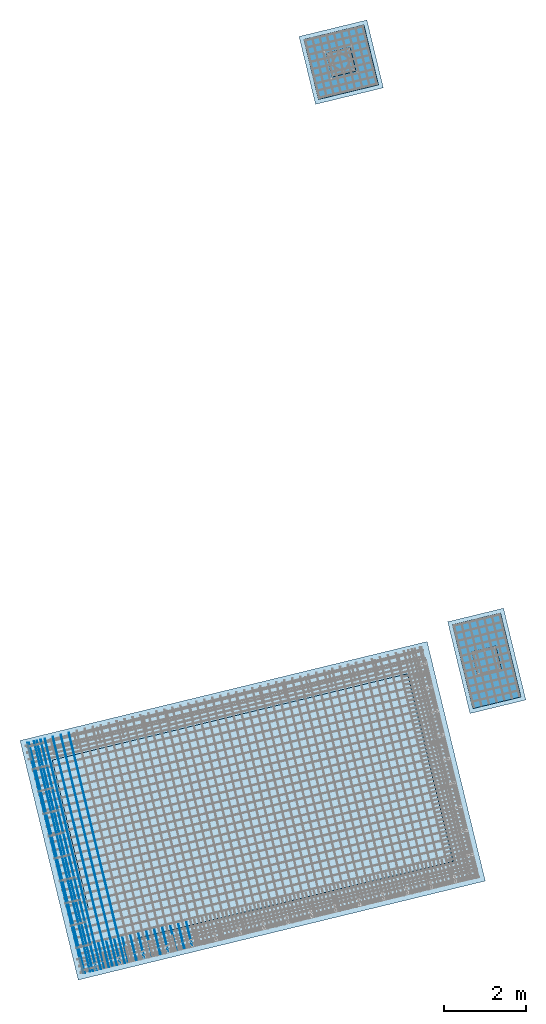
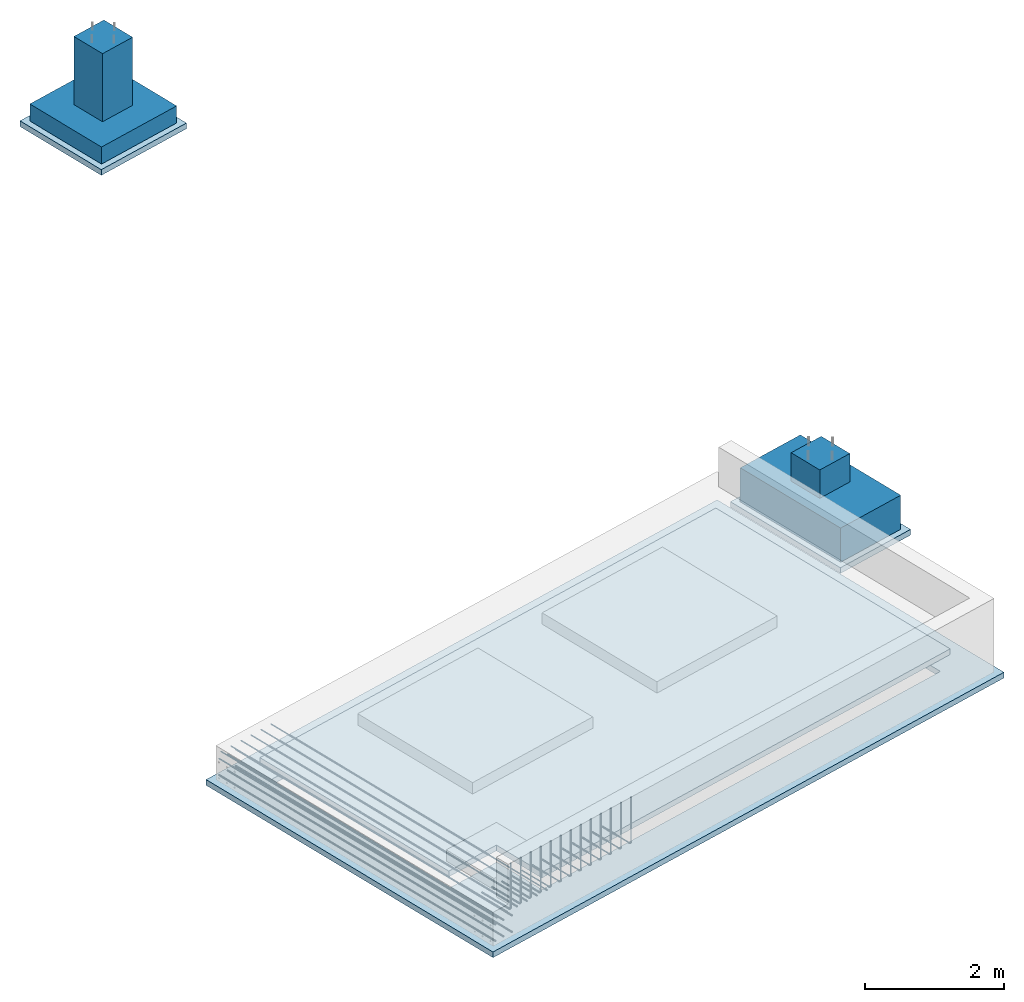
# One storey, part 1 of 25: 25 reinforcing bars, 6 slabs, 1 opening.
"""IFC2X3 building model written with IfcOpenShell, lengths in millimetres."""

from ifc_helpers import new_model, entity, si_unit, converted_unit, derived_unit, direction, frame, frame_2d, origin, origin_2d_with_axis, place, context, subcontext, project, spatial, polyline, rectangle, outline, extrude, faceted_brep, material, layer, layer_set, layer_usage, type_object, element, save


model = new_model("IFC2X3")

# Units and contexts
model_context = context("Model", 3, precision=0.01, world=origin(), true_north=direction((6.12303176911189e-17, 1.0)))
body_context = subcontext(model_context, "Body", "Model", "MODEL_VIEW")
ifc_project = project(units=[si_unit("LENGTHUNIT", "METRE", prefix="MILLI"), si_unit("AREAUNIT", "SQUARE_METRE"), si_unit("VOLUMEUNIT", "CUBIC_METRE"), converted_unit("PLANEANGLEUNIT", "DEGREE", entity("IfcRatioMeasure", 0.0174532925199433), si_unit("PLANEANGLEUNIT", "RADIAN"), dimensions=[0, 0, 0, 0, 0, 0, 0]), si_unit("MASSUNIT", "GRAM", prefix="KILO"), derived_unit("MASSDENSITYUNIT", [(si_unit("MASSUNIT", "GRAM", prefix="KILO"), 1), (si_unit("LENGTHUNIT", "METRE"), -3)]), derived_unit("MOMENTOFINERTIAUNIT", [(si_unit("LENGTHUNIT", "METRE"), 4)]), si_unit("TIMEUNIT", "SECOND"), si_unit("FREQUENCYUNIT", "HERTZ"), si_unit("THERMODYNAMICTEMPERATUREUNIT", "DEGREE_CELSIUS"), derived_unit("THERMALTRANSMITTANCEUNIT", [(si_unit("MASSUNIT", "GRAM", prefix="KILO"), 1), (si_unit("THERMODYNAMICTEMPERATUREUNIT", "KELVIN"), -1), (si_unit("TIMEUNIT", "SECOND"), -3)]), derived_unit("VOLUMETRICFLOWRATEUNIT", [(si_unit("LENGTHUNIT", "METRE"), 3), (si_unit("TIMEUNIT", "SECOND"), -1)]), derived_unit("MASSFLOWRATEUNIT", [(si_unit("MASSUNIT", "GRAM", prefix="KILO"), 1), (si_unit("TIMEUNIT", "SECOND"), -1)]), derived_unit("ROTATIONALFREQUENCYUNIT", [(si_unit("TIMEUNIT", "SECOND"), -1)]), si_unit("ELECTRICCURRENTUNIT", "AMPERE"), si_unit("ELECTRICVOLTAGEUNIT", "VOLT"), si_unit("POWERUNIT", "WATT"), si_unit("FORCEUNIT", "NEWTON", prefix="KILO"), si_unit("ILLUMINANCEUNIT", "LUX"), si_unit("LUMINOUSFLUXUNIT", "LUMEN"), si_unit("LUMINOUSINTENSITYUNIT", "CANDELA"), derived_unit("USERDEFINED", [(si_unit("MASSUNIT", "GRAM", prefix="KILO"), -1), (si_unit("LENGTHUNIT", "METRE"), -2), (si_unit("TIMEUNIT", "SECOND"), 3), (si_unit("LUMINOUSFLUXUNIT", "LUMEN"), 1)]), derived_unit("LINEARVELOCITYUNIT", [(si_unit("LENGTHUNIT", "METRE"), 1), (si_unit("TIMEUNIT", "SECOND"), -1)]), si_unit("PRESSUREUNIT", "PASCAL"), derived_unit("USERDEFINED", [(si_unit("LENGTHUNIT", "METRE"), -2), (si_unit("MASSUNIT", "GRAM", prefix="KILO"), 1), (si_unit("TIMEUNIT", "SECOND"), -2)]), derived_unit("LINEARFORCEUNIT", [(si_unit("MASSUNIT", "GRAM", prefix="KILO"), 1), (si_unit("LENGTHUNIT", "METRE"), 1), (si_unit("TIMEUNIT", "SECOND"), -2), (si_unit("LENGTHUNIT", "METRE"), -1)]), derived_unit("PLANARFORCEUNIT", [(si_unit("MASSUNIT", "GRAM", prefix="KILO"), 1), (si_unit("LENGTHUNIT", "METRE"), 1), (si_unit("TIMEUNIT", "SECOND"), -2), (si_unit("LENGTHUNIT", "METRE"), -2)])], contexts=[model_context])

# Site, building, storey
site_placement = place(None, frame((19171.75, -72498.58, 0.0), z_axis=(0.0, 0.0, 1.0), x_axis=(0.971695960795463, 0.236234967296933, 0.0)))
site = spatial("IfcSite", under=ifc_project, at=site_placement, CompositionType="ELEMENT")
building_placement = place(site_placement, origin())
building = spatial("IfcBuilding", under=site, at=building_placement, CompositionType="ELEMENT")
storey_placement = place(building_placement, origin())
storey = spatial("IfcBuildingStorey", under=building, at=storey_placement, Name="01", CompositionType="ELEMENT", Elevation=0.0)

# Slab, opening
ifc_material_1 = material()
ifc_layer = layer(ifc_material_1, 100.0)
ifc_layer_set = layer_set([ifc_layer], Name=":ADSK_ 7.5_100")
ifc_layer_usage = layer_usage(ifc_layer_set, "AXIS3", "POSITIVE", 0.0)
slab_type_1 = type_object("IfcSlabType", Name=":ADSK_ 7.5_100", PredefinedType="BASESLAB", material=ifc_layer_set)
slab_1_placement = place(storey_placement, frame((-100.0, -100.0, -700.0)))
slab_1 = element("IfcSlab", 1, at=slab_1_placement, inside=storey, type_object=slab_type_1, material=ifc_layer_usage, Name=":ADSK_ 7.5_100", ObjectType=":ADSK_ 7.5_100", PredefinedType="BASESLAB", context=body_context, shape_type="SweptSolid", body=[
    extrude(rectangle(XDim=10200.0, YDim=6000.00000000003, at=frame_2d((0.0, 0.0), x_axis=(-1.0, 0.0))), frame((5100.0, 3000.0, 100.0), z_axis=(0.0, 0.0, -1.0), x_axis=(-1.0, 0.0, 0.0)), (0.0, 0.0, 1.0), 100.0),
])
opening_placement = place(slab_1_placement, frame((3933.33, 2533.33, 100.0)))
element("IfcOpeningElement", 2, at=opening_placement, cuts=slab_1, Name=":ADSK_ 7.5_100:2", ObjectType="Opening", context=body_context, shape_type="SweptSolid", body=[
    extrude(outline(polyline([(-933.33, 3283.33), (-933.33, 2333.33), (-1883.33, 2333.33), (-1883.33, -5616.67), (2816.67, -5616.67), (2816.67, 3283.33), (-933.33, 3283.33)])), frame((0.0, 0.0, 0.0), z_axis=(0.0, 0.0, 1.0), x_axis=(0.0, 1.0, 0.0)), (0.0, 0.0, -1.0), 100.0),
])

# Slabs
slab_type_2 = type_object("IfcSlabType", Name=":ADSK_ 7.5_100", PredefinedType="BASESLAB", material=ifc_layer_set)
placement = place(storey_placement, origin())
element("IfcSlab", 3, at=placement, inside=storey, type_object=slab_type_2, material=ifc_layer_usage, Name=":ADSK_ 7.5_100", ObjectType=":ADSK_ 7.5_100", PredefinedType="BASESLAB", context=body_context, shape_type="SweptSolid", body=[
    extrude(outline(polyline([(-1000.0, -3350.0), (2950.0, -3350.0), (2950.0, 5750.0), (-1950.0, 5750.0), (-1950.0, -2400.0), (-1000.0, -2400.0), (-1000.0, -3350.0)])), frame((3800.0, 2400.0, -200.0), z_axis=(0.0, 0.0, -1.0), x_axis=(0.0, 1.0, 0.0)), (0.0, 0.0, 1.0), 100.0),
])
slab_type_3 = type_object("IfcSlabType", Name="_:2", PredefinedType="BASESLAB")
slab_3_placement = place(storey_placement, frame((10800.0, 4050.0, -1100.0)))
element("IfcSlab", 4, at=slab_3_placement, inside=storey, type_object=slab_type_3, Name="_:2", ObjectType="_:2", PredefinedType="BASESLAB", context=body_context, shape_type="Brep", body=[
    faceted_brep([(300.0, 750.0, 1100.0), (900.0, 750.0, 1100.0), (900.0, 1350.0, 1100.0), (300.0, 1350.0, 1100.0), (300.0, 750.0, 600.0), (900.0, 750.0, 600.0), (900.0, 1350.0, 600.0), (300.0, 1350.0, 600.0), (0.0, 0.0, 600.0), (1200.0, 0.0, 600.0), (1200.0, 2100.0, 600.0), (0.0, 2100.0, 600.0), (0.0, 0.0, 0.0), (0.0, 2100.0, 0.0), (1200.0, 2100.0, 0.0), (1200.0, 0.0, 0.0)], [[[0, 1, 2, 3]], [[1, 0, 4, 5]], [[2, 1, 5, 6]], [[3, 2, 6, 7]], [[0, 3, 7, 4]], [[5, 4, 7, 6], [8, 9, 10, 11]], [[12, 13, 14, 15]], [[9, 8, 12, 15]], [[10, 9, 15, 14]], [[11, 10, 14, 13]], [[8, 11, 13, 12]]], outer=[[True], [True], [True], [True], [True], [False, True], [True], [True], [True], [True], [True]]),
])
slab_type_4 = type_object("IfcSlabType", Name="_:1", PredefinedType="BASESLAB")
slab_4_placement = place(storey_placement, frame((10650.0, 19350.0, -1760.0)))
element("IfcSlab", 5, at=slab_4_placement, inside=storey, type_object=slab_type_4, Name="_:1", ObjectType="_:1", PredefinedType="BASESLAB", context=body_context, shape_type="Brep", body=[
    faceted_brep([(450.0, 450.0, 1500.0), (1050.0, 450.0, 1500.0), (1050.0, 1050.0, 1500.0), (450.0, 1050.0, 1500.0), (450.0, 450.0, 300.0), (1050.0, 450.0, 300.0), (1050.0, 1050.0, 300.0), (450.0, 1050.0, 300.0), (0.0, 0.0, 300.0), (1500.0, 0.0, 300.0), (1500.0, 1500.0, 300.0), (0.0, 1500.0, 300.0), (0.0, 0.0, 0.0), (0.0, 1500.0, 0.0), (1500.0, 1500.0, 0.0), (1500.0, 0.0, 0.0)], [[[0, 1, 2, 3]], [[1, 0, 4, 5]], [[2, 1, 5, 6]], [[3, 2, 6, 7]], [[0, 3, 7, 4]], [[5, 4, 7, 6], [8, 9, 10, 11]], [[12, 13, 14, 15]], [[9, 8, 12, 15]], [[10, 9, 15, 14]], [[11, 10, 14, 13]], [[8, 11, 13, 12]]], outer=[[True], [True], [True], [True], [True], [False, True], [True], [True], [True], [True], [True]]),
])
slab_type_5 = type_object("IfcSlabType", Name=":ADSK_ 7.5_100", PredefinedType="BASESLAB", material=ifc_layer_set)
element("IfcSlab", 6, at=placement, inside=storey, type_object=slab_type_5, material=ifc_layer_usage, Name=":ADSK_ 7.5_100", ObjectType=":ADSK_ 7.5_100", PredefinedType="BASESLAB", context=body_context, shape_type="SweptSolid", body=[
    extrude(rectangle(XDim=2300.0, YDim=1400.0, at=origin_2d_with_axis()), frame((11400.0, 5100.0, -1100.0), z_axis=(0.0, 0.0, -1.0), x_axis=(0.0, 1.0, 0.0)), (0.0, 0.0, 1.0), 100.0),
])
slab_type_6 = type_object("IfcSlabType", Name=":ADSK_ 7.5_100", PredefinedType="BASESLAB", material=ifc_layer_set)
element("IfcSlab", 7, at=placement, inside=storey, type_object=slab_type_6, material=ifc_layer_usage, Name=":ADSK_ 7.5_100", ObjectType=":ADSK_ 7.5_100", PredefinedType="BASESLAB", context=body_context, shape_type="SweptSolid", body=[
    extrude(rectangle(XDim=1700.0, YDim=1700.0, at=origin_2d_with_axis()), frame((11400.0, 20100.0, -1760.0), z_axis=(0.0, 0.0, -1.0), x_axis=(0.0, 1.0, 0.0)), (0.0, 0.0, 1.0), 100.0),
])

# Reinforcing bars
ifc_material_2 = material(Name="500")
element("IfcReinforcingBar", 8, at=placement, inside=storey, material=ifc_material_2, ObjectType=":500 14_Bottom bar", BarLength=5775.0, BarRole="NOTDEFINED", CrossSectionArea=0.0001539380400259, NominalDiameter=14.0, context=body_context, shape_type="AdvancedSweptSolid", body=[
    entity("IfcSweptDiskSolid", entity("IfcCompositeCurve", [entity("IfcCompositeCurveSegment", "CONTINUOUS", True, entity("IfcPolyline", [entity("IfcCartesianPoint", [1100.0, 5800.0, -150.0]), entity("IfcCartesianPoint", [1100.0, 25.0, -150.0])]))], False), 7.0, None, 0.0, 1.0),
])
element("IfcReinforcingBar", 9, at=placement, inside=storey, material=ifc_material_2, ObjectType=":500 14_Bottom bar", BarLength=5775.0, BarRole="NOTDEFINED", CrossSectionArea=0.0001539380400259, NominalDiameter=14.0, context=body_context, shape_type="AdvancedSweptSolid", body=[
    entity("IfcSweptDiskSolid", entity("IfcCompositeCurve", [entity("IfcCompositeCurveSegment", "CONTINUOUS", True, entity("IfcPolyline", [entity("IfcCartesianPoint", [900.0, 5800.0, -150.0]), entity("IfcCartesianPoint", [900.0, 25.0, -150.0])]))], False), 7.0, None, 0.0, 1.0),
])
element("IfcReinforcingBar", 10, at=placement, inside=storey, material=ifc_material_2, ObjectType=":500 14_Bottom bar", BarLength=5775.0, BarRole="NOTDEFINED", CrossSectionArea=0.0001539380400259, NominalDiameter=14.0, context=body_context, shape_type="AdvancedSweptSolid", body=[
    entity("IfcSweptDiskSolid", entity("IfcCompositeCurve", [entity("IfcCompositeCurveSegment", "CONTINUOUS", True, entity("IfcPolyline", [entity("IfcCartesianPoint", [700.0, 5800.0, -150.0]), entity("IfcCartesianPoint", [700.0, 25.0, -150.0])]))], False), 7.0, None, 0.0, 1.0),
])
element("IfcReinforcingBar", 11, at=placement, inside=storey, material=ifc_material_2, ObjectType=":500 14_Bottom bar", BarLength=5775.0, BarRole="NOTDEFINED", CrossSectionArea=0.0001539380400259, NominalDiameter=14.0, context=body_context, shape_type="AdvancedSweptSolid", body=[
    entity("IfcSweptDiskSolid", entity("IfcCompositeCurve", [entity("IfcCompositeCurveSegment", "CONTINUOUS", True, entity("IfcPolyline", [entity("IfcCartesianPoint", [500.0, 5800.0, -150.0]), entity("IfcCartesianPoint", [500.0, 25.0, -150.0])]))], False), 7.0, None, 0.0, 1.0),
])
element("IfcReinforcingBar", 12, at=placement, inside=storey, material=ifc_material_2, ObjectType=":500 14_Bottom bar", BarLength=5775.0, BarRole="NOTDEFINED", CrossSectionArea=0.0001539380400259, NominalDiameter=14.0, context=body_context, shape_type="AdvancedSweptSolid", body=[
    entity("IfcSweptDiskSolid", entity("IfcCompositeCurve", [entity("IfcCompositeCurveSegment", "CONTINUOUS", True, entity("IfcPolyline", [entity("IfcCartesianPoint", [300.0, 5800.0, -150.0]), entity("IfcCartesianPoint", [300.0, 25.0, -150.0])]))], False), 7.0, None, 0.0, 1.0),
])
element("IfcReinforcingBar", 13, at=placement, inside=storey, material=ifc_material_2, ObjectType=":500 14_Bottom bar", BarLength=5775.0, BarRole="NOTDEFINED", CrossSectionArea=0.0001539380400259, NominalDiameter=14.0, context=body_context, shape_type="AdvancedSweptSolid", body=[
    entity("IfcSweptDiskSolid", entity("IfcCompositeCurve", [entity("IfcCompositeCurveSegment", "CONTINUOUS", True, entity("IfcPolyline", [entity("IfcCartesianPoint", [100.0, 5800.0, -150.0]), entity("IfcCartesianPoint", [100.0, 25.0, -150.0])]))], False), 7.0, None, 0.0, 1.0),
])
element("IfcReinforcingBar", 14, at=placement, inside=storey, material=ifc_material_2, ObjectType=":500 14_Bottom bar", BarLength=5775.0, BarRole="NOTDEFINED", CrossSectionArea=0.0001539380400259, NominalDiameter=14.0, context=body_context, shape_type="AdvancedSweptSolid", body=[
    entity("IfcSweptDiskSolid", entity("IfcCompositeCurve", [entity("IfcCompositeCurveSegment", "CONTINUOUS", True, entity("IfcPolyline", [entity("IfcCartesianPoint", [65.69, 5800.0, -257.81]), entity("IfcCartesianPoint", [65.69, 25.0, -257.81])]))], False), 7.0, None, 0.0, 1.0),
])
element("IfcReinforcingBar", 15, at=placement, inside=storey, material=ifc_material_2, ObjectType=":500 14_Bottom bar", BarLength=5775.0, BarRole="NOTDEFINED", CrossSectionArea=0.0001539380400259, NominalDiameter=14.0, context=body_context, shape_type="AdvancedSweptSolid", body=[
    entity("IfcSweptDiskSolid", entity("IfcCompositeCurve", [entity("IfcCompositeCurveSegment", "CONTINUOUS", True, entity("IfcPolyline", [entity("IfcCartesianPoint", [395.69, 5800.0, -257.81]), entity("IfcCartesianPoint", [395.69, 25.0, -257.81])]))], False), 7.0, None, 0.0, 1.0),
])
element("IfcReinforcingBar", 16, at=placement, inside=storey, material=ifc_material_2, ObjectType=":500 14_Bottom bar", BarLength=5775.0, BarRole="NOTDEFINED", CrossSectionArea=0.0001539380400259, NominalDiameter=14.0, context=body_context, shape_type="AdvancedSweptSolid", body=[
    entity("IfcSweptDiskSolid", entity("IfcCompositeCurve", [entity("IfcCompositeCurveSegment", "CONTINUOUS", True, entity("IfcPolyline", [entity("IfcCartesianPoint", [230.69, 5800.0, -257.81]), entity("IfcCartesianPoint", [230.69, 25.0, -257.81])]))], False), 7.0, None, 0.0, 1.0),
])
element("IfcReinforcingBar", 17, at=placement, inside=storey, material=ifc_material_2, ObjectType=":500 14_Bottom bar", BarLength=5775.0, BarRole="NOTDEFINED", CrossSectionArea=0.0001539380400259, NominalDiameter=14.0, context=body_context, shape_type="AdvancedSweptSolid", body=[
    entity("IfcSweptDiskSolid", entity("IfcCompositeCurve", [entity("IfcCompositeCurveSegment", "CONTINUOUS", True, entity("IfcPolyline", [entity("IfcCartesianPoint", [65.69, 5800.0, -547.81]), entity("IfcCartesianPoint", [65.69, 25.0, -547.81])]))], False), 7.0, None, 0.0, 1.0),
])
element("IfcReinforcingBar", 18, at=placement, inside=storey, material=ifc_material_2, ObjectType=":500 14_Bottom bar", BarLength=5775.0, BarRole="NOTDEFINED", CrossSectionArea=0.0001539380400259, NominalDiameter=14.0, context=body_context, shape_type="AdvancedSweptSolid", body=[
    entity("IfcSweptDiskSolid", entity("IfcCompositeCurve", [entity("IfcCompositeCurveSegment", "CONTINUOUS", True, entity("IfcPolyline", [entity("IfcCartesianPoint", [395.69, 5800.0, -547.81]), entity("IfcCartesianPoint", [395.69, 25.0, -547.81])]))], False), 7.0, None, 0.0, 1.0),
])
element("IfcReinforcingBar", 19, at=placement, inside=storey, material=ifc_material_2, ObjectType=":500 14_Bottom bar", BarLength=5775.0, BarRole="NOTDEFINED", CrossSectionArea=0.0001539380400259, NominalDiameter=14.0, context=body_context, shape_type="AdvancedSweptSolid", body=[
    entity("IfcSweptDiskSolid", entity("IfcCompositeCurve", [entity("IfcCompositeCurveSegment", "CONTINUOUS", True, entity("IfcPolyline", [entity("IfcCartesianPoint", [230.69, 5800.0, -547.81]), entity("IfcCartesianPoint", [230.69, 25.0, -547.81])]))], False), 7.0, None, 0.0, 1.0),
])
element("IfcReinforcingBar", 20, at=placement, inside=storey, material=ifc_material_2, ObjectType=":500 14_Wall bar", BarLength=1400.0, BarRole="NOTDEFINED", CrossSectionArea=0.0001539380400259, NominalDiameter=14.0, context=body_context, shape_type="AdvancedSweptSolid", body=[
    entity("IfcSweptDiskSolid", entity("IfcCompositeCurve", [entity("IfcCompositeCurveSegment", "CONTINUOUS", True, entity("IfcPolyline", [entity("IfcCartesianPoint", [393.15, 44.74, 655.7]), entity("IfcCartesianPoint", [393.15, 44.74, -122.3])])), entity("IfcCompositeCurveSegment", "CONTINUOUS", True, entity("IfcTrimmedCurve", entity("IfcCircle", entity("IfcAxis2Placement3D", entity("IfcCartesianPoint", [393.15, 86.74, -122.3]), entity("IfcDirection", [1.0, 0.0, 0.0]), entity("IfcDirection", [0.0, 0.0, -1.0])), 42.0), [entity("IfcParameterValue", 270.0)], [entity("IfcParameterValue", 360.0)], True, "PARAMETER")), entity("IfcCompositeCurveSegment", "CONTINUOUS", True, entity("IfcPolyline", [entity("IfcCartesianPoint", [393.15, 86.74, -164.3]), entity("IfcCartesianPoint", [393.15, 644.74, -164.3])]))], False), 7.0, None, 0.0, 92.0000000000001),
])
element("IfcReinforcingBar", 21, at=placement, inside=storey, material=ifc_material_2, ObjectType=":500 14_Wall bar", BarLength=1400.0, BarRole="NOTDEFINED", CrossSectionArea=0.0001539380400259, NominalDiameter=14.0, context=body_context, shape_type="AdvancedSweptSolid", body=[
    entity("IfcSweptDiskSolid", entity("IfcCompositeCurve", [entity("IfcCompositeCurveSegment", "CONTINUOUS", True, entity("IfcPolyline", [entity("IfcCartesianPoint", [593.15, 44.74, 655.7]), entity("IfcCartesianPoint", [593.15, 44.74, -122.3])])), entity("IfcCompositeCurveSegment", "CONTINUOUS", True, entity("IfcTrimmedCurve", entity("IfcCircle", entity("IfcAxis2Placement3D", entity("IfcCartesianPoint", [593.15, 86.74, -122.3]), entity("IfcDirection", [1.0, 0.0, 0.0]), entity("IfcDirection", [0.0, 0.0, -1.0])), 42.0), [entity("IfcParameterValue", 270.0)], [entity("IfcParameterValue", 360.0)], True, "PARAMETER")), entity("IfcCompositeCurveSegment", "CONTINUOUS", True, entity("IfcPolyline", [entity("IfcCartesianPoint", [593.15, 86.74, -164.3]), entity("IfcCartesianPoint", [593.15, 644.74, -164.3])]))], False), 7.0, None, 0.0, 92.0000000000001),
])
element("IfcReinforcingBar", 22, at=placement, inside=storey, material=ifc_material_2, ObjectType=":500 14_Wall bar", BarLength=1400.0, BarRole="NOTDEFINED", CrossSectionArea=0.0001539380400259, NominalDiameter=14.0, context=body_context, shape_type="AdvancedSweptSolid", body=[
    entity("IfcSweptDiskSolid", entity("IfcCompositeCurve", [entity("IfcCompositeCurveSegment", "CONTINUOUS", True, entity("IfcPolyline", [entity("IfcCartesianPoint", [793.15, 44.74, 655.7]), entity("IfcCartesianPoint", [793.15, 44.74, -122.3])])), entity("IfcCompositeCurveSegment", "CONTINUOUS", True, entity("IfcTrimmedCurve", entity("IfcCircle", entity("IfcAxis2Placement3D", entity("IfcCartesianPoint", [793.15, 86.74, -122.3]), entity("IfcDirection", [1.0, 0.0, 0.0]), entity("IfcDirection", [0.0, 0.0, -1.0])), 42.0), [entity("IfcParameterValue", 270.0)], [entity("IfcParameterValue", 360.0)], True, "PARAMETER")), entity("IfcCompositeCurveSegment", "CONTINUOUS", True, entity("IfcPolyline", [entity("IfcCartesianPoint", [793.15, 86.74, -164.3]), entity("IfcCartesianPoint", [793.15, 644.74, -164.3])]))], False), 7.0, None, 0.0, 92.0000000000001),
])
element("IfcReinforcingBar", 23, at=placement, inside=storey, material=ifc_material_2, ObjectType=":500 14_Wall bar", BarLength=1400.0, BarRole="NOTDEFINED", CrossSectionArea=0.0001539380400259, NominalDiameter=14.0, context=body_context, shape_type="AdvancedSweptSolid", body=[
    entity("IfcSweptDiskSolid", entity("IfcCompositeCurve", [entity("IfcCompositeCurveSegment", "CONTINUOUS", True, entity("IfcPolyline", [entity("IfcCartesianPoint", [993.15, 44.74, 655.7]), entity("IfcCartesianPoint", [993.15, 44.74, -122.3])])), entity("IfcCompositeCurveSegment", "CONTINUOUS", True, entity("IfcTrimmedCurve", entity("IfcCircle", entity("IfcAxis2Placement3D", entity("IfcCartesianPoint", [993.15, 86.74, -122.3]), entity("IfcDirection", [1.0, 0.0, 0.0]), entity("IfcDirection", [0.0, 0.0, -1.0])), 42.0), [entity("IfcParameterValue", 270.0)], [entity("IfcParameterValue", 360.0)], True, "PARAMETER")), entity("IfcCompositeCurveSegment", "CONTINUOUS", True, entity("IfcPolyline", [entity("IfcCartesianPoint", [993.15, 86.74, -164.3]), entity("IfcCartesianPoint", [993.15, 644.74, -164.3])]))], False), 7.0, None, 0.0, 92.0000000000001),
])
element("IfcReinforcingBar", 24, at=placement, inside=storey, material=ifc_material_2, ObjectType=":500 14_Wall bar", BarLength=1400.0, BarRole="NOTDEFINED", CrossSectionArea=0.0001539380400259, NominalDiameter=14.0, context=body_context, shape_type="AdvancedSweptSolid", body=[
    entity("IfcSweptDiskSolid", entity("IfcCompositeCurve", [entity("IfcCompositeCurveSegment", "CONTINUOUS", True, entity("IfcPolyline", [entity("IfcCartesianPoint", [1193.15, 44.74, 655.7]), entity("IfcCartesianPoint", [1193.15, 44.74, -122.3])])), entity("IfcCompositeCurveSegment", "CONTINUOUS", True, entity("IfcTrimmedCurve", entity("IfcCircle", entity("IfcAxis2Placement3D", entity("IfcCartesianPoint", [1193.15, 86.74, -122.3]), entity("IfcDirection", [1.0, 0.0, 0.0]), entity("IfcDirection", [0.0, 0.0, -1.0])), 42.0), [entity("IfcParameterValue", 270.0)], [entity("IfcParameterValue", 360.0)], True, "PARAMETER")), entity("IfcCompositeCurveSegment", "CONTINUOUS", True, entity("IfcPolyline", [entity("IfcCartesianPoint", [1193.15, 86.74, -164.3]), entity("IfcCartesianPoint", [1193.15, 644.74, -164.3])]))], False), 7.0, None, 0.0, 92.0000000000001),
])
element("IfcReinforcingBar", 25, at=placement, inside=storey, material=ifc_material_2, ObjectType=":500 14_Wall bar", BarLength=1400.0, BarRole="NOTDEFINED", CrossSectionArea=0.0001539380400259, NominalDiameter=14.0, context=body_context, shape_type="AdvancedSweptSolid", body=[
    entity("IfcSweptDiskSolid", entity("IfcCompositeCurve", [entity("IfcCompositeCurveSegment", "CONTINUOUS", True, entity("IfcPolyline", [entity("IfcCartesianPoint", [1393.15, 44.74, 655.7]), entity("IfcCartesianPoint", [1393.15, 44.74, -122.3])])), entity("IfcCompositeCurveSegment", "CONTINUOUS", True, entity("IfcTrimmedCurve", entity("IfcCircle", entity("IfcAxis2Placement3D", entity("IfcCartesianPoint", [1393.15, 86.74, -122.3]), entity("IfcDirection", [1.0, 0.0, 0.0]), entity("IfcDirection", [0.0, 0.0, -1.0])), 42.0), [entity("IfcParameterValue", 270.0)], [entity("IfcParameterValue", 360.0)], True, "PARAMETER")), entity("IfcCompositeCurveSegment", "CONTINUOUS", True, entity("IfcPolyline", [entity("IfcCartesianPoint", [1393.15, 86.74, -164.3]), entity("IfcCartesianPoint", [1393.15, 644.74, -164.3])]))], False), 7.0, None, 0.0, 92.0000000000001),
])
element("IfcReinforcingBar", 26, at=placement, inside=storey, material=ifc_material_2, ObjectType=":500 14_Wall bar", BarLength=1400.0, BarRole="NOTDEFINED", CrossSectionArea=0.0001539380400259, NominalDiameter=14.0, context=body_context, shape_type="AdvancedSweptSolid", body=[
    entity("IfcSweptDiskSolid", entity("IfcCompositeCurve", [entity("IfcCompositeCurveSegment", "CONTINUOUS", True, entity("IfcPolyline", [entity("IfcCartesianPoint", [1593.15, 44.74, 655.7]), entity("IfcCartesianPoint", [1593.15, 44.74, -122.3])])), entity("IfcCompositeCurveSegment", "CONTINUOUS", True, entity("IfcTrimmedCurve", entity("IfcCircle", entity("IfcAxis2Placement3D", entity("IfcCartesianPoint", [1593.15, 86.74, -122.3]), entity("IfcDirection", [1.0, 0.0, 0.0]), entity("IfcDirection", [0.0, 0.0, -1.0])), 42.0), [entity("IfcParameterValue", 270.0)], [entity("IfcParameterValue", 360.0)], True, "PARAMETER")), entity("IfcCompositeCurveSegment", "CONTINUOUS", True, entity("IfcPolyline", [entity("IfcCartesianPoint", [1593.15, 86.74, -164.3]), entity("IfcCartesianPoint", [1593.15, 644.74, -164.3])]))], False), 7.0, None, 0.0, 92.0000000000001),
])
element("IfcReinforcingBar", 27, at=placement, inside=storey, material=ifc_material_2, ObjectType=":500 14_Wall bar", BarLength=1400.0, BarRole="NOTDEFINED", CrossSectionArea=0.0001539380400259, NominalDiameter=14.0, context=body_context, shape_type="AdvancedSweptSolid", body=[
    entity("IfcSweptDiskSolid", entity("IfcCompositeCurve", [entity("IfcCompositeCurveSegment", "CONTINUOUS", True, entity("IfcPolyline", [entity("IfcCartesianPoint", [1793.15, 44.74, 655.7]), entity("IfcCartesianPoint", [1793.15, 44.74, -122.3])])), entity("IfcCompositeCurveSegment", "CONTINUOUS", True, entity("IfcTrimmedCurve", entity("IfcCircle", entity("IfcAxis2Placement3D", entity("IfcCartesianPoint", [1793.15, 86.74, -122.3]), entity("IfcDirection", [1.0, 0.0, 0.0]), entity("IfcDirection", [0.0, 0.0, -1.0])), 42.0), [entity("IfcParameterValue", 270.0)], [entity("IfcParameterValue", 360.0)], True, "PARAMETER")), entity("IfcCompositeCurveSegment", "CONTINUOUS", True, entity("IfcPolyline", [entity("IfcCartesianPoint", [1793.15, 86.74, -164.3]), entity("IfcCartesianPoint", [1793.15, 644.74, -164.3])]))], False), 7.0, None, 0.0, 92.0000000000001),
])
element("IfcReinforcingBar", 28, at=placement, inside=storey, material=ifc_material_2, ObjectType=":500 14_Wall bar", BarLength=1400.0, BarRole="NOTDEFINED", CrossSectionArea=0.0001539380400259, NominalDiameter=14.0, context=body_context, shape_type="AdvancedSweptSolid", body=[
    entity("IfcSweptDiskSolid", entity("IfcCompositeCurve", [entity("IfcCompositeCurveSegment", "CONTINUOUS", True, entity("IfcPolyline", [entity("IfcCartesianPoint", [1993.15, 44.74, 655.7]), entity("IfcCartesianPoint", [1993.15, 44.74, -122.3])])), entity("IfcCompositeCurveSegment", "CONTINUOUS", True, entity("IfcTrimmedCurve", entity("IfcCircle", entity("IfcAxis2Placement3D", entity("IfcCartesianPoint", [1993.15, 86.74, -122.3]), entity("IfcDirection", [1.0, 0.0, 0.0]), entity("IfcDirection", [0.0, 0.0, -1.0])), 42.0), [entity("IfcParameterValue", 270.0)], [entity("IfcParameterValue", 360.0)], True, "PARAMETER")), entity("IfcCompositeCurveSegment", "CONTINUOUS", True, entity("IfcPolyline", [entity("IfcCartesianPoint", [1993.15, 86.74, -164.3]), entity("IfcCartesianPoint", [1993.15, 644.74, -164.3])]))], False), 7.0, None, 0.0, 92.0000000000001),
])
element("IfcReinforcingBar", 29, at=placement, inside=storey, material=ifc_material_2, ObjectType=":500 14_Wall bar", BarLength=1400.0, BarRole="NOTDEFINED", CrossSectionArea=0.0001539380400259, NominalDiameter=14.0, context=body_context, shape_type="AdvancedSweptSolid", body=[
    entity("IfcSweptDiskSolid", entity("IfcCompositeCurve", [entity("IfcCompositeCurveSegment", "CONTINUOUS", True, entity("IfcPolyline", [entity("IfcCartesianPoint", [2193.15, 44.74, 655.7]), entity("IfcCartesianPoint", [2193.15, 44.74, -122.3])])), entity("IfcCompositeCurveSegment", "CONTINUOUS", True, entity("IfcTrimmedCurve", entity("IfcCircle", entity("IfcAxis2Placement3D", entity("IfcCartesianPoint", [2193.15, 86.74, -122.3]), entity("IfcDirection", [1.0, 0.0, 0.0]), entity("IfcDirection", [0.0, 0.0, -1.0])), 42.0), [entity("IfcParameterValue", 270.0)], [entity("IfcParameterValue", 360.0)], True, "PARAMETER")), entity("IfcCompositeCurveSegment", "CONTINUOUS", True, entity("IfcPolyline", [entity("IfcCartesianPoint", [2193.15, 86.74, -164.3]), entity("IfcCartesianPoint", [2193.15, 644.74, -164.3])]))], False), 7.0, None, 0.0, 92.0000000000001),
])
element("IfcReinforcingBar", 30, at=placement, inside=storey, material=ifc_material_2, ObjectType=":500 14_Wall bar", BarLength=1400.0, BarRole="NOTDEFINED", CrossSectionArea=0.0001539380400259, NominalDiameter=14.0, context=body_context, shape_type="AdvancedSweptSolid", body=[
    entity("IfcSweptDiskSolid", entity("IfcCompositeCurve", [entity("IfcCompositeCurveSegment", "CONTINUOUS", True, entity("IfcPolyline", [entity("IfcCartesianPoint", [2393.15, 44.74, 655.7]), entity("IfcCartesianPoint", [2393.15, 44.74, -122.3])])), entity("IfcCompositeCurveSegment", "CONTINUOUS", True, entity("IfcTrimmedCurve", entity("IfcCircle", entity("IfcAxis2Placement3D", entity("IfcCartesianPoint", [2393.15, 86.74, -122.3]), entity("IfcDirection", [1.0, 0.0, 0.0]), entity("IfcDirection", [0.0, 0.0, -1.0])), 42.0), [entity("IfcParameterValue", 270.0)], [entity("IfcParameterValue", 360.0)], True, "PARAMETER")), entity("IfcCompositeCurveSegment", "CONTINUOUS", True, entity("IfcPolyline", [entity("IfcCartesianPoint", [2393.15, 86.74, -164.3]), entity("IfcCartesianPoint", [2393.15, 644.74, -164.3])]))], False), 7.0, None, 0.0, 92.0000000000001),
])
element("IfcReinforcingBar", 31, at=placement, inside=storey, material=ifc_material_2, ObjectType=":500 14_Wall bar", BarLength=1400.0, BarRole="NOTDEFINED", CrossSectionArea=0.0001539380400259, NominalDiameter=14.0, context=body_context, shape_type="AdvancedSweptSolid", body=[
    entity("IfcSweptDiskSolid", entity("IfcCompositeCurve", [entity("IfcCompositeCurveSegment", "CONTINUOUS", True, entity("IfcPolyline", [entity("IfcCartesianPoint", [2593.15, 44.74, 655.7]), entity("IfcCartesianPoint", [2593.15, 44.74, -122.3])])), entity("IfcCompositeCurveSegment", "CONTINUOUS", True, entity("IfcTrimmedCurve", entity("IfcCircle", entity("IfcAxis2Placement3D", entity("IfcCartesianPoint", [2593.15, 86.74, -122.3]), entity("IfcDirection", [1.0, 0.0, 0.0]), entity("IfcDirection", [0.0, 0.0, -1.0])), 42.0), [entity("IfcParameterValue", 270.0)], [entity("IfcParameterValue", 360.0)], True, "PARAMETER")), entity("IfcCompositeCurveSegment", "CONTINUOUS", True, entity("IfcPolyline", [entity("IfcCartesianPoint", [2593.15, 86.74, -164.3]), entity("IfcCartesianPoint", [2593.15, 644.74, -164.3])]))], False), 7.0, None, 0.0, 92.0000000000001),
])
element("IfcReinforcingBar", 32, at=placement, inside=storey, material=ifc_material_2, ObjectType=":500 14_Wall bar", BarLength=1400.0, BarRole="NOTDEFINED", CrossSectionArea=0.0001539380400259, NominalDiameter=14.0, context=body_context, shape_type="AdvancedSweptSolid", body=[
    entity("IfcSweptDiskSolid", entity("IfcCompositeCurve", [entity("IfcCompositeCurveSegment", "CONTINUOUS", True, entity("IfcPolyline", [entity("IfcCartesianPoint", [2793.15, 44.74, 655.7]), entity("IfcCartesianPoint", [2793.15, 44.74, -122.3])])), entity("IfcCompositeCurveSegment", "CONTINUOUS", True, entity("IfcTrimmedCurve", entity("IfcCircle", entity("IfcAxis2Placement3D", entity("IfcCartesianPoint", [2793.15, 86.74, -122.3]), entity("IfcDirection", [1.0, 0.0, 0.0]), entity("IfcDirection", [0.0, 0.0, -1.0])), 42.0), [entity("IfcParameterValue", 270.0)], [entity("IfcParameterValue", 360.0)], True, "PARAMETER")), entity("IfcCompositeCurveSegment", "CONTINUOUS", True, entity("IfcPolyline", [entity("IfcCartesianPoint", [2793.15, 86.74, -164.3]), entity("IfcCartesianPoint", [2793.15, 644.74, -164.3])]))], False), 7.0, None, 0.0, 92.0000000000001),
])

save(model, "model.ifc")
